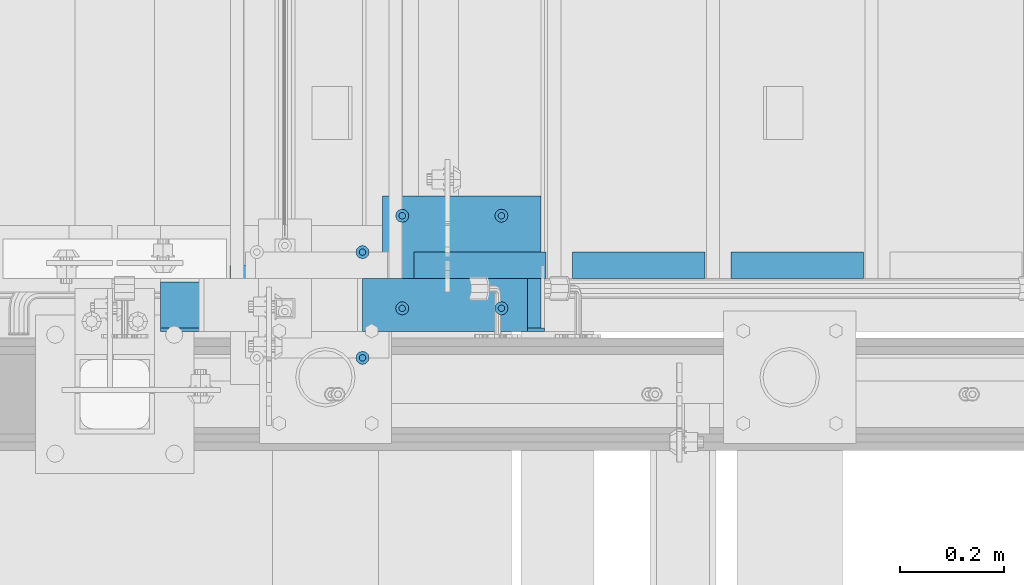
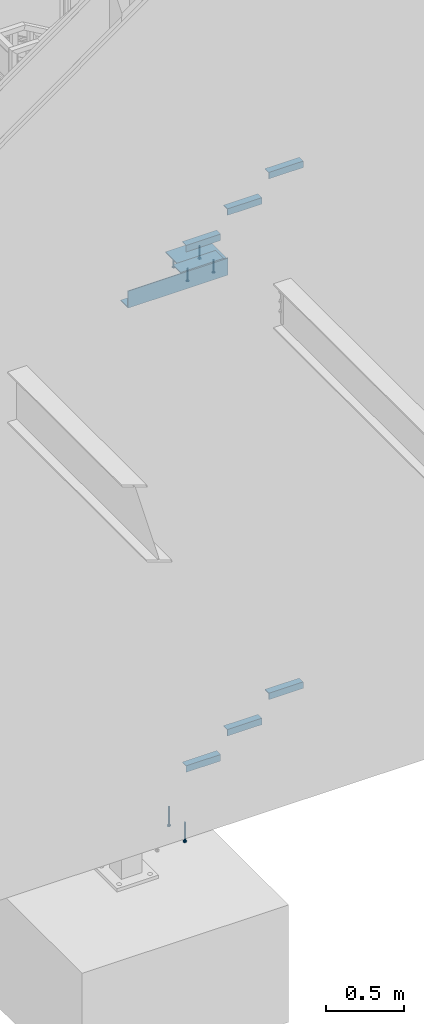
# One storey, part 905 of 1179: 15 beams, 5 elements without a shape of their own.
"""IFC2X3 building model written with IfcOpenShell, lengths in millimetres."""

from ifc_helpers import new_model, si_unit, frame, origin_with_axes, place, context, subcontext, project, spatial, faceted_brep, material, type_object, element, aggregate, save


model = new_model("IFC2X3")

# Units and contexts
model_context = context("Model", 3, precision=1e-05, world=origin_with_axes())
body_context = subcontext(model_context, "Body", "Model", "MODEL_VIEW")
ifc_project = project(units=[si_unit("LENGTHUNIT", "METRE", prefix="MILLI"), si_unit("AREAUNIT", "SQUARE_METRE"), si_unit("VOLUMEUNIT", "CUBIC_METRE"), si_unit("MASSUNIT", "GRAM", prefix="KILO"), si_unit("TIMEUNIT", "SECOND"), si_unit("PLANEANGLEUNIT", "RADIAN"), si_unit("SOLIDANGLEUNIT", "STERADIAN"), si_unit("THERMODYNAMICTEMPERATUREUNIT", "DEGREE_CELSIUS"), si_unit("LUMINOUSINTENSITYUNIT", "LUMEN")], contexts=[model_context])

# Site, building, storey
site_placement = place(None, origin_with_axes())
site = spatial("IfcSite", under=ifc_project, at=site_placement, CompositionType="ELEMENT")
building_placement = place(site_placement, origin_with_axes())
building = spatial("IfcBuilding", under=site, at=building_placement, Name="Undefined", CompositionType="ELEMENT")
storey_placement = place(building_placement, origin_with_axes())
storey = spatial("IfcBuildingStorey", under=building, at=storey_placement, Name="Undefined", CompositionType="ELEMENT", Elevation=0.0)

# Assembly, beams
assembly_1_placement = place(storey_placement, origin_with_axes())
assembly_1 = element("IfcElementAssembly", 1, at=assembly_1_placement, inside=storey, Name="STAIR", AssemblyPlace="NOTDEFINED", PredefinedType="RIGID_FRAME")
ifc_material_1 = material(Name="STEEL/A36")
beam_type_1 = type_object("IfcBeamType", Name="L2X2X3/16", PredefinedType="NOTDEFINED")
beam_1_placement = place(assembly_1_placement, frame((20717.213033546, 38233.3500001282, 4690.07030000019), z_axis=(0.0, 1.0, 0.0), x_axis=(-1.0, 0.0, 0.0)))
beam_1 = element("IfcBeam", 2, at=beam_1_placement, type_object=beam_type_1, material=ifc_material_1, Name="ANGLE", ObjectType="L2X2X3/16", context=body_context, shape_type="Brep", body=[
    faceted_brep([(0.0, 25.3999999999996, -25.4000000000015), (0.0, 25.3999999999996, 25.4000000000015), (254.0, 25.3999999999996, 25.4000000000001), (254.0, 25.3999999999996, -25.4000000000001), (0.0, 20.6374999999998, 25.4000000000015), (254.0, 20.6374999999998, 25.4000000000001), (0.0, 20.6374999999998, -20.6374999999971), (254.0, 20.6374999999998, -20.6374999999998), (0.0, -25.3999999999996, -20.6374999999971), (254.0, -25.3999999999996, -20.6374999999998), (0.0, -25.3999999999996, -25.4000000000015), (254.0, -25.3999999999996, -25.4000000000001)], [[[0, 1, 2, 3]], [[1, 4, 5, 2]], [[4, 6, 7, 5]], [[6, 8, 9, 7]], [[8, 10, 11, 9]], [[10, 0, 3, 11]], [[5, 7, 9, 11, 3, 2]], [[10, 8, 6, 4, 1, 0]]]),
])
beam_2_placement = place(assembly_1_placement, frame((20412.4130335689, 38233.3500001282, 4512.27030000019), z_axis=(0.0, 1.0, 0.0), x_axis=(-1.0, 0.0, 0.0)))
beam_2 = element("IfcBeam", 3, at=beam_2_placement, type_object=beam_type_1, material=ifc_material_1, Name="ANGLE", ObjectType="L2X2X3/16", context=body_context, shape_type="Brep", body=[
    faceted_brep([(0.0, 25.3999999999996, -25.4000000000015), (0.0, 25.3999999999996, 25.4000000000015), (254.0, 25.3999999999996, 25.4000000000001), (254.0, 25.3999999999996, -25.4000000000001), (0.0, 20.6374999999998, 25.4000000000015), (254.0, 20.6374999999998, 25.4000000000001), (0.0, 20.6374999999998, -20.6374999999971), (254.0, 20.6374999999998, -20.6374999999998), (0.0, -25.3999999999996, -20.6374999999971), (254.0, -25.3999999999996, -20.6374999999998), (0.0, -25.3999999999996, -25.4000000000015), (254.0, -25.3999999999996, -25.4000000000001)], [[[0, 1, 2, 3]], [[1, 4, 5, 2]], [[4, 6, 7, 5]], [[6, 8, 9, 7]], [[8, 10, 11, 9]], [[10, 0, 3, 11]], [[5, 7, 9, 11, 3, 2]], [[10, 8, 6, 4, 1, 0]]]),
])
beam_3_placement = place(assembly_1_placement, frame((20107.6130335918, 38233.3500001282, 4334.47030000019), z_axis=(0.0, 1.0, 0.0), x_axis=(-1.0, 0.0, 0.0)))
beam_3 = element("IfcBeam", 4, at=beam_3_placement, type_object=beam_type_1, material=ifc_material_1, Name="ANGLE", ObjectType="L2X2X3/16", context=body_context, shape_type="Brep", body=[
    faceted_brep([(0.0, 25.3999999999996, -25.4000000000015), (0.0, 25.3999999999996, 25.4000000000015), (254.0, 25.3999999999996, 25.4000000000001), (254.0, 25.3999999999996, -25.4000000000001), (0.0, 20.6374999999998, 25.4000000000015), (254.0, 20.6374999999998, 25.4000000000001), (0.0, 20.6374999999998, -20.6374999999971), (254.0, 20.6374999999998, -20.6374999999998), (0.0, -25.3999999999996, -20.6374999999971), (254.0, -25.3999999999996, -20.6374999999998), (0.0, -25.3999999999996, -25.4000000000015), (254.0, -25.3999999999996, -25.4000000000001)], [[[0, 1, 2, 3]], [[1, 4, 5, 2]], [[4, 6, 7, 5]], [[6, 8, 9, 7]], [[8, 10, 11, 9]], [[10, 0, 3, 11]], [[5, 7, 9, 11, 3, 2]], [[10, 8, 6, 4, 1, 0]]]),
])

assembly_2_placement = place(storey_placement, origin_with_axes())
assembly_2 = element("IfcElementAssembly", 5, at=assembly_2_placement, inside=storey, Name="STAIR", AssemblyPlace="NOTDEFINED", PredefinedType="RIGID_FRAME")
beam_4_placement = place(assembly_2_placement, frame((20717.2678270794, 38233.3500000346, 627.128633117604), z_axis=(0.0, 1.0, 0.0), x_axis=(-1.0, 0.0, 0.0)))
beam_4 = element("IfcBeam", 6, at=beam_4_placement, type_object=beam_type_1, material=ifc_material_1, Name="ANGLE", ObjectType="L2X2X3/16", context=body_context, shape_type="Brep", body=[
    faceted_brep([(0.0, 25.3999999999996, -25.4000000000015), (0.0, 25.3999999999996, 25.4000000000015), (254.0, 25.3999999999996, 25.4000000000001), (254.0, 25.3999999999996, -25.4000000000001), (0.0, 20.6374999999998, 25.4000000000015), (254.0, 20.6374999999998, 25.4000000000001), (0.0, 20.6374999999998, -20.6374999999971), (254.0, 20.6374999999998, -20.6374999999998), (0.0, -25.3999999999996, -20.6374999999971), (254.0, -25.3999999999996, -20.6374999999998), (0.0, -25.3999999999996, -25.4000000000015), (254.0, -25.3999999999996, -25.4000000000001)], [[[0, 1, 2, 3]], [[1, 4, 5, 2]], [[4, 6, 7, 5]], [[6, 8, 9, 7]], [[8, 10, 11, 9]], [[10, 0, 3, 11]], [[5, 7, 9, 11, 3, 2]], [[10, 8, 6, 4, 1, 0]]]),
])
beam_5_placement = place(assembly_2_placement, frame((20412.4678270527, 38233.3500000359, 450.651549838405), z_axis=(0.0, 1.0, 0.0), x_axis=(-1.0, 0.0, 0.0)))
beam_5 = element("IfcBeam", 7, at=beam_5_placement, type_object=beam_type_1, material=ifc_material_1, Name="ANGLE", ObjectType="L2X2X3/16", context=body_context, shape_type="Brep", body=[
    faceted_brep([(0.0, 25.3999999999996, -25.4000000000015), (0.0, 25.3999999999996, 25.4000000000015), (254.0, 25.3999999999996, 25.4000000000001), (254.0, 25.3999999999996, -25.4000000000001), (0.0, 20.6374999999998, 25.4000000000015), (254.0, 20.6374999999998, 25.4000000000001), (0.0, 20.6374999999998, -20.6374999999971), (254.0, 20.6374999999998, -20.6374999999998), (0.0, -25.3999999999996, -20.6374999999971), (254.0, -25.3999999999996, -20.6374999999998), (0.0, -25.3999999999996, -25.4000000000015), (254.0, -25.3999999999996, -25.4000000000001)], [[[0, 1, 2, 3]], [[1, 4, 5, 2]], [[4, 6, 7, 5]], [[6, 8, 9, 7]], [[8, 10, 11, 9]], [[10, 0, 3, 11]], [[5, 7, 9, 11, 3, 2]], [[10, 8, 6, 4, 1, 0]]]),
])
beam_6_placement = place(assembly_2_placement, frame((20107.6678270259, 38233.3500000371, 274.174466559207), z_axis=(0.0, 1.0, 0.0), x_axis=(-1.0, 0.0, 0.0)))
beam_6 = element("IfcBeam", 8, at=beam_6_placement, type_object=beam_type_1, material=ifc_material_1, Name="ANGLE", ObjectType="L2X2X3/16", context=body_context, shape_type="Brep", body=[
    faceted_brep([(0.0, 25.3999999999996, -25.4000000000015), (0.0, 25.3999999999996, 25.4000000000015), (254.0, 25.3999999999996, 25.4000000000001), (254.0, 25.3999999999996, -25.4000000000001), (0.0, 20.6374999999998, 25.4000000000015), (254.0, 20.6374999999998, 25.4000000000001), (0.0, 20.6374999999998, -20.6374999999971), (254.0, 20.6374999999998, -20.6374999999998), (0.0, -25.3999999999996, -20.6374999999971), (254.0, -25.3999999999996, -20.6374999999998), (0.0, -25.3999999999996, -25.4000000000015), (254.0, -25.3999999999996, -25.4000000000001)], [[[0, 1, 2, 3]], [[1, 4, 5, 2]], [[4, 6, 7, 5]], [[6, 8, 9, 7]], [[8, 10, 11, 9]], [[10, 0, 3, 11]], [[5, 7, 9, 11, 3, 2]], [[10, 8, 6, 4, 1, 0]]]),
])
aggregate(assembly_2, [beam_4, beam_5, beam_6])

assembly_3_placement = place(storey_placement, origin_with_axes())
assembly_3 = element("IfcElementAssembly", 9, at=assembly_3_placement, inside=storey, Name="EMBED", AssemblyPlace="NOTDEFINED", PredefinedType="RIGID_FRAME")
ifc_material_2 = material(Name="STEEL/A108")
beam_type_2 = type_object("IfcBeamType", Name="STUD_1/2-DIA", PredefinedType="NOTDEFINED")
beam_7_placement = place(assembly_3_placement, frame((20021.55, 38150.8000000005, 4225.925), z_axis=(0.0, -1.0, 0.0), x_axis=(0.0, 0.0, -1.0)))
beam_7 = element("IfcBeam", 10, at=beam_7_placement, type_object=beam_type_2, material=ifc_material_2, Name="SHEAR STUD", ObjectType="STUD_1/2-DIA", context=body_context, shape_type="Brep", body=[
    faceted_brep([(0.0, -3.1800000667572, 5.5), (0.0, -5.5, 3.1800000667572), (94.4880000000003, -5.5, 3.1800000667572), (94.4880000000003, -3.1800000667572, 5.5), (0.0, -6.34999999999854, 0.0), (94.4880000000003, -6.34999990463257, 0.0), (0.0, -5.5, -3.1800000667572), (94.4880000000003, -5.5, -3.1800000667572), (0.0, -3.1800000667572, -5.5), (94.4880000000003, -3.1800000667572, -5.5), (0.0, 0.0, -6.34999999999991), (94.4880000000003, 0.0, -6.34999990463257), (0.0, 3.1800000667572, -5.5), (94.4880000000003, 3.1800000667572, -5.5), (0.0, 5.5, -3.1800000667572), (94.4880000000003, 5.5, -3.1800000667572), (0.0, 6.34999999999854, 0.0), (94.4880000000003, 6.34999990463257, 0.0), (0.0, 5.5, 3.1800000667572), (94.4880000000003, 5.5, 3.1800000667572), (0.0, 3.1800000667572, 5.5), (94.4880000000003, 3.1800000667572, 5.5), (0.0, 0.0, 6.34999999999991), (94.4880000000003, 0.0, 6.34999990463257), (96.5200000000004, -10.9899997711182, 6.34999990463257), (96.5200000000004, -6.34000015258789, 10.9899997711182), (96.5200000000004, -12.6999998092651, 0.0), (96.5200000000004, -10.9899997711182, -6.34999990463257), (96.5200000000004, -6.34000015258789, -10.9899997711182), (96.5200000000004, 0.0, -12.6899995803833), (96.5200000000004, 6.34000015258789, -10.9899997711182), (96.5200000000004, 10.9899997711182, -6.34999990463257), (96.5200000000004, 12.6999998092651, 0.0), (96.5200000000004, 10.9899997711182, 6.34999990463257), (96.5200000000004, 6.34000015258789, 10.9899997711182), (96.5200000000004, 0.0, 12.6899995803833), (101.6, -10.9899997711182, 6.34999990463257), (101.6, -6.34000015258789, 10.9899997711182), (101.6, -12.6999998092651, 0.0), (101.6, -10.9899997711182, -6.34999990463257), (101.6, -6.34000015258789, -10.9899997711182), (101.6, 0.0, -12.6899995803833), (101.6, 6.34000015258789, -10.9899997711182), (101.6, 10.9899997711182, -6.34999990463257), (101.6, 12.6999998092651, 0.0), (101.6, 10.9899997711182, 6.34999990463257), (101.6, 6.34000015258789, 10.9899997711182), (101.6, 0.0, 12.6899995803833)], [[[0, 1, 2, 3]], [[1, 4, 5, 2]], [[4, 6, 7, 5]], [[6, 8, 9, 7]], [[8, 10, 11, 9]], [[10, 12, 13, 11]], [[12, 14, 15, 13]], [[14, 16, 17, 15]], [[16, 18, 19, 17]], [[18, 20, 21, 19]], [[20, 22, 23, 21]], [[22, 0, 3, 23]], [[22, 20, 18, 16, 14, 12, 10, 8, 6, 4, 1, 0]], [[3, 2, 24, 25]], [[2, 5, 26, 24]], [[5, 7, 27, 26]], [[7, 9, 28, 27]], [[9, 11, 29, 28]], [[11, 13, 30, 29]], [[13, 15, 31, 30]], [[15, 17, 32, 31]], [[17, 19, 33, 32]], [[19, 21, 34, 33]], [[21, 23, 35, 34]], [[23, 3, 25, 35]], [[25, 24, 36, 37]], [[24, 26, 38, 36]], [[26, 27, 39, 38]], [[27, 28, 40, 39]], [[28, 29, 41, 40]], [[29, 30, 42, 41]], [[30, 31, 43, 42]], [[31, 32, 44, 43]], [[32, 33, 45, 44]], [[33, 34, 46, 45]], [[34, 35, 47, 46]], [[35, 25, 37, 47]], [[38, 39, 40, 41, 42, 43, 44, 45, 46, 47, 37, 36]]]),
])
beam_8_placement = place(assembly_3_placement, frame((19831.05, 38150.8000000005, 4225.925), z_axis=(0.0, -1.0, 0.0), x_axis=(0.0, 0.0, -1.0)))
beam_8 = element("IfcBeam", 11, at=beam_8_placement, type_object=beam_type_2, material=ifc_material_2, Name="SHEAR STUD", ObjectType="STUD_1/2-DIA", context=body_context, shape_type="Brep", body=[
    faceted_brep([(0.0, -3.1800000667572, 5.5), (0.0, -5.5, 3.1800000667572), (94.4880000000003, -5.5, 3.1800000667572), (94.4880000000003, -3.1800000667572, 5.5), (0.0, -6.34999999999854, 0.0), (94.4880000000003, -6.34999990463257, 0.0), (0.0, -5.5, -3.1800000667572), (94.4880000000003, -5.5, -3.1800000667572), (0.0, -3.1800000667572, -5.5), (94.4880000000003, -3.1800000667572, -5.5), (0.0, 0.0, -6.34999999999991), (94.4880000000003, 0.0, -6.34999990463257), (0.0, 3.1800000667572, -5.5), (94.4880000000003, 3.1800000667572, -5.5), (0.0, 5.5, -3.1800000667572), (94.4880000000003, 5.5, -3.1800000667572), (0.0, 6.34999999999854, 0.0), (94.4880000000003, 6.34999990463257, 0.0), (0.0, 5.5, 3.1800000667572), (94.4880000000003, 5.5, 3.1800000667572), (0.0, 3.1800000667572, 5.5), (94.4880000000003, 3.1800000667572, 5.5), (0.0, 0.0, 6.34999999999991), (94.4880000000003, 0.0, 6.34999990463257), (96.5200000000004, -10.9899997711182, 6.34999990463257), (96.5200000000004, -6.34000015258789, 10.9899997711182), (96.5200000000004, -12.6999998092651, 0.0), (96.5200000000004, -10.9899997711182, -6.34999990463257), (96.5200000000004, -6.34000015258789, -10.9899997711182), (96.5200000000004, 0.0, -12.6899995803833), (96.5200000000004, 6.34000015258789, -10.9899997711182), (96.5200000000004, 10.9899997711182, -6.34999990463257), (96.5200000000004, 12.6999998092651, 0.0), (96.5200000000004, 10.9899997711182, 6.34999990463257), (96.5200000000004, 6.34000015258789, 10.9899997711182), (96.5200000000004, 0.0, 12.6899995803833), (101.6, -10.9899997711182, 6.34999990463257), (101.6, -6.34000015258789, 10.9899997711182), (101.6, -12.6999998092651, 0.0), (101.6, -10.9899997711182, -6.34999990463257), (101.6, -6.34000015258789, -10.9899997711182), (101.6, 0.0, -12.6899995803833), (101.6, 6.34000015258789, -10.9899997711182), (101.6, 10.9899997711182, -6.34999990463257), (101.6, 12.6999998092651, 0.0), (101.6, 10.9899997711182, 6.34999990463257), (101.6, 6.34000015258789, 10.9899997711182), (101.6, 0.0, 12.6899995803833)], [[[0, 1, 2, 3]], [[1, 4, 5, 2]], [[4, 6, 7, 5]], [[6, 8, 9, 7]], [[8, 10, 11, 9]], [[10, 12, 13, 11]], [[12, 14, 15, 13]], [[14, 16, 17, 15]], [[16, 18, 19, 17]], [[18, 20, 21, 19]], [[20, 22, 23, 21]], [[22, 0, 3, 23]], [[22, 20, 18, 16, 14, 12, 10, 8, 6, 4, 1, 0]], [[3, 2, 24, 25]], [[2, 5, 26, 24]], [[5, 7, 27, 26]], [[7, 9, 28, 27]], [[9, 11, 29, 28]], [[11, 13, 30, 29]], [[13, 15, 31, 30]], [[15, 17, 32, 31]], [[17, 19, 33, 32]], [[19, 21, 34, 33]], [[21, 23, 35, 34]], [[23, 3, 25, 35]], [[25, 24, 36, 37]], [[24, 26, 38, 36]], [[26, 27, 39, 38]], [[27, 28, 40, 39]], [[28, 29, 41, 40]], [[29, 30, 42, 41]], [[30, 31, 43, 42]], [[31, 32, 44, 43]], [[32, 33, 45, 44]], [[33, 34, 46, 45]], [[34, 35, 47, 46]], [[35, 25, 37, 47]], [[38, 39, 40, 41, 42, 43, 44, 45, 46, 47, 37, 36]]]),
])
beam_9_placement = place(assembly_3_placement, frame((20021.55, 38328.6000000005, 4225.925), z_axis=(0.0, -1.0, 0.0), x_axis=(0.0, 0.0, -1.0)))
beam_9 = element("IfcBeam", 12, at=beam_9_placement, type_object=beam_type_2, material=ifc_material_2, Name="SHEAR STUD", ObjectType="STUD_1/2-DIA", context=body_context, shape_type="Brep", body=[
    faceted_brep([(0.0, -3.1800000667572, 5.5), (0.0, -5.5, 3.1800000667572), (94.4880000000003, -5.5, 3.1800000667572), (94.4880000000003, -3.1800000667572, 5.5), (0.0, -6.34999999999854, 0.0), (94.4880000000003, -6.34999990463257, 0.0), (0.0, -5.5, -3.1800000667572), (94.4880000000003, -5.5, -3.1800000667572), (0.0, -3.1800000667572, -5.5), (94.4880000000003, -3.1800000667572, -5.5), (0.0, 0.0, -6.34999999999991), (94.4880000000003, 0.0, -6.34999990463257), (0.0, 3.1800000667572, -5.5), (94.4880000000003, 3.1800000667572, -5.5), (0.0, 5.5, -3.1800000667572), (94.4880000000003, 5.5, -3.1800000667572), (0.0, 6.34999999999854, 0.0), (94.4880000000003, 6.34999990463257, 0.0), (0.0, 5.5, 3.1800000667572), (94.4880000000003, 5.5, 3.1800000667572), (0.0, 3.1800000667572, 5.5), (94.4880000000003, 3.1800000667572, 5.5), (0.0, 0.0, 6.34999999999991), (94.4880000000003, 0.0, 6.34999990463257), (96.5200000000004, -10.9899997711182, 6.34999990463257), (96.5200000000004, -6.34000015258789, 10.9899997711182), (96.5200000000004, -12.6999998092651, 0.0), (96.5200000000004, -10.9899997711182, -6.34999990463257), (96.5200000000004, -6.34000015258789, -10.9899997711182), (96.5200000000004, 0.0, -12.6899995803833), (96.5200000000004, 6.34000015258789, -10.9899997711182), (96.5200000000004, 10.9899997711182, -6.34999990463257), (96.5200000000004, 12.6999998092651, 0.0), (96.5200000000004, 10.9899997711182, 6.34999990463257), (96.5200000000004, 6.34000015258789, 10.9899997711182), (96.5200000000004, 0.0, 12.6899995803833), (101.6, -10.9899997711182, 6.34999990463257), (101.6, -6.34000015258789, 10.9899997711182), (101.6, -12.6999998092651, 0.0), (101.6, -10.9899997711182, -6.34999990463257), (101.6, -6.34000015258789, -10.9899997711182), (101.6, 0.0, -12.6899995803833), (101.6, 6.34000015258789, -10.9899997711182), (101.6, 10.9899997711182, -6.34999990463257), (101.6, 12.6999998092651, 0.0), (101.6, 10.9899997711182, 6.34999990463257), (101.6, 6.34000015258789, 10.9899997711182), (101.6, 0.0, 12.6899995803833)], [[[0, 1, 2, 3]], [[1, 4, 5, 2]], [[4, 6, 7, 5]], [[6, 8, 9, 7]], [[8, 10, 11, 9]], [[10, 12, 13, 11]], [[12, 14, 15, 13]], [[14, 16, 17, 15]], [[16, 18, 19, 17]], [[18, 20, 21, 19]], [[20, 22, 23, 21]], [[22, 0, 3, 23]], [[22, 20, 18, 16, 14, 12, 10, 8, 6, 4, 1, 0]], [[3, 2, 24, 25]], [[2, 5, 26, 24]], [[5, 7, 27, 26]], [[7, 9, 28, 27]], [[9, 11, 29, 28]], [[11, 13, 30, 29]], [[13, 15, 31, 30]], [[15, 17, 32, 31]], [[17, 19, 33, 32]], [[19, 21, 34, 33]], [[21, 23, 35, 34]], [[23, 3, 25, 35]], [[25, 24, 36, 37]], [[24, 26, 38, 36]], [[26, 27, 39, 38]], [[27, 28, 40, 39]], [[28, 29, 41, 40]], [[29, 30, 42, 41]], [[30, 31, 43, 42]], [[31, 32, 44, 43]], [[32, 33, 45, 44]], [[33, 34, 46, 45]], [[34, 35, 47, 46]], [[35, 25, 37, 47]], [[38, 39, 40, 41, 42, 43, 44, 45, 46, 47, 37, 36]]]),
])
beam_10_placement = place(assembly_3_placement, frame((19831.05, 38328.6000000005, 4225.925), z_axis=(0.0, -1.0, 0.0), x_axis=(0.0, 0.0, -1.0)))
beam_10 = element("IfcBeam", 13, at=beam_10_placement, type_object=beam_type_2, material=ifc_material_2, Name="SHEAR STUD", ObjectType="STUD_1/2-DIA", context=body_context, shape_type="Brep", body=[
    faceted_brep([(0.0, -3.1800000667572, 5.5), (0.0, -5.5, 3.1800000667572), (94.4880000000003, -5.5, 3.1800000667572), (94.4880000000003, -3.1800000667572, 5.5), (0.0, -6.34999999999854, 0.0), (94.4880000000003, -6.34999990463257, 0.0), (0.0, -5.5, -3.1800000667572), (94.4880000000003, -5.5, -3.1800000667572), (0.0, -3.1800000667572, -5.5), (94.4880000000003, -3.1800000667572, -5.5), (0.0, 0.0, -6.34999999999991), (94.4880000000003, 0.0, -6.34999990463257), (0.0, 3.1800000667572, -5.5), (94.4880000000003, 3.1800000667572, -5.5), (0.0, 5.5, -3.1800000667572), (94.4880000000003, 5.5, -3.1800000667572), (0.0, 6.34999999999854, 0.0), (94.4880000000003, 6.34999990463257, 0.0), (0.0, 5.5, 3.1800000667572), (94.4880000000003, 5.5, 3.1800000667572), (0.0, 3.1800000667572, 5.5), (94.4880000000003, 3.1800000667572, 5.5), (0.0, 0.0, 6.34999999999991), (94.4880000000003, 0.0, 6.34999990463257), (96.5200000000004, -10.9899997711182, 6.34999990463257), (96.5200000000004, -6.34000015258789, 10.9899997711182), (96.5200000000004, -12.6999998092651, 0.0), (96.5200000000004, -10.9899997711182, -6.34999990463257), (96.5200000000004, -6.34000015258789, -10.9899997711182), (96.5200000000004, 0.0, -12.6899995803833), (96.5200000000004, 6.34000015258789, -10.9899997711182), (96.5200000000004, 10.9899997711182, -6.34999990463257), (96.5200000000004, 12.6999998092651, 0.0), (96.5200000000004, 10.9899997711182, 6.34999990463257), (96.5200000000004, 6.34000015258789, 10.9899997711182), (96.5200000000004, 0.0, 12.6899995803833), (101.6, -10.9899997711182, 6.34999990463257), (101.6, -6.34000015258789, 10.9899997711182), (101.6, -12.6999998092651, 0.0), (101.6, -10.9899997711182, -6.34999990463257), (101.6, -6.34000015258789, -10.9899997711182), (101.6, 0.0, -12.6899995803833), (101.6, 6.34000015258789, -10.9899997711182), (101.6, 10.9899997711182, -6.34999990463257), (101.6, 12.6999998092651, 0.0), (101.6, 10.9899997711182, 6.34999990463257), (101.6, 6.34000015258789, 10.9899997711182), (101.6, 0.0, 12.6899995803833)], [[[0, 1, 2, 3]], [[1, 4, 5, 2]], [[4, 6, 7, 5]], [[6, 8, 9, 7]], [[8, 10, 11, 9]], [[10, 12, 13, 11]], [[12, 14, 15, 13]], [[14, 16, 17, 15]], [[16, 18, 19, 17]], [[18, 20, 21, 19]], [[20, 22, 23, 21]], [[22, 0, 3, 23]], [[22, 20, 18, 16, 14, 12, 10, 8, 6, 4, 1, 0]], [[3, 2, 24, 25]], [[2, 5, 26, 24]], [[5, 7, 27, 26]], [[7, 9, 28, 27]], [[9, 11, 29, 28]], [[11, 13, 30, 29]], [[13, 15, 31, 30]], [[15, 17, 32, 31]], [[17, 19, 33, 32]], [[19, 21, 34, 33]], [[21, 23, 35, 34]], [[23, 3, 25, 35]], [[25, 24, 36, 37]], [[24, 26, 38, 36]], [[26, 27, 39, 38]], [[27, 28, 40, 39]], [[28, 29, 41, 40]], [[29, 30, 42, 41]], [[30, 31, 43, 42]], [[31, 32, 44, 43]], [[32, 33, 45, 44]], [[33, 34, 46, 45]], [[34, 35, 47, 46]], [[35, 25, 37, 47]], [[38, 39, 40, 41, 42, 43, 44, 45, 46, 47, 37, 36]]]),
])

assembly_4_placement = place(storey_placement, origin_with_axes())
assembly_4 = element("IfcElementAssembly", 14, at=assembly_4_placement, inside=storey, Name="EMBED", AssemblyPlace="NOTDEFINED", PredefinedType="RIGID_FRAME")
beam_11_placement = place(assembly_4_placement, frame((19754.8500003795, 38055.5499999969, -12.6999999999994), z_axis=(0.0, -1.0, 0.0), x_axis=(0.0, 0.0, -1.0)))
beam_11 = element("IfcBeam", 15, at=beam_11_placement, type_object=beam_type_2, material=ifc_material_2, Name="SHEAR STUD", ObjectType="STUD_1/2-DIA", context=body_context, shape_type="Brep", body=[
    faceted_brep([(0.0, -3.1800000667572, 5.5), (0.0, -5.5, 3.1800000667572), (141.732, -5.5, 3.1800000667572), (141.732, -3.1800000667572, 5.5), (0.0, -6.34999999999854, 0.0), (141.732, -6.34999990463257, 0.0), (0.0, -5.5, -3.1800000667572), (141.732, -5.5, -3.1800000667572), (0.0, -3.1800000667572, -5.5), (141.732, -3.1800000667572, -5.5), (0.0, 0.0, -6.34999999999991), (141.732, 0.0, -6.34999990463257), (0.0, 3.1800000667572, -5.5), (141.732, 3.1800000667572, -5.5), (0.0, 5.5, -3.1800000667572), (141.732, 5.5, -3.1800000667572), (0.0, 6.34999999999854, 0.0), (141.732, 6.34999990463257, 0.0), (0.0, 5.5, 3.1800000667572), (141.732, 5.5, 3.1800000667572), (0.0, 3.1800000667572, 5.5), (141.732, 3.1800000667572, 5.5), (0.0, 0.0, 6.34999999999991), (141.732, 0.0, 6.34999990463257), (144.78, -10.9899997711182, 6.34999990463257), (144.78, -6.34000015258789, 10.9899997711182), (144.78, -12.6999998092651, 0.0), (144.78, -10.9899997711182, -6.34999990463257), (144.78, -6.34000015258789, -10.9899997711182), (144.78, 0.0, -12.6899995803833), (144.78, 6.34000015258789, -10.9899997711182), (144.78, 10.9899997711182, -6.34999990463257), (144.78, 12.6999998092651, 0.0), (144.78, 10.9899997711182, 6.34999990463257), (144.78, 6.34000015258789, 10.9899997711182), (144.78, 0.0, 12.6899995803833), (152.4, -10.9899997711182, 6.34999990463257), (152.4, -6.34000015258789, 10.9899997711182), (152.4, -12.6999998092651, 0.0), (152.4, -10.9899997711182, -6.34999990463257), (152.4, -6.34000015258789, -10.9899997711182), (152.4, 0.0, -12.6899995803833), (152.4, 6.34000015258789, -10.9899997711182), (152.4, 10.9899997711182, -6.34999990463257), (152.4, 12.6999998092651, 0.0), (152.4, 10.9899997711182, 6.34999990463257), (152.4, 6.34000015258789, 10.9899997711182), (152.4, 0.0, 12.6899995803833)], [[[0, 1, 2, 3]], [[1, 4, 5, 2]], [[4, 6, 7, 5]], [[6, 8, 9, 7]], [[8, 10, 11, 9]], [[10, 12, 13, 11]], [[12, 14, 15, 13]], [[14, 16, 17, 15]], [[16, 18, 19, 17]], [[18, 20, 21, 19]], [[20, 22, 23, 21]], [[22, 0, 3, 23]], [[22, 20, 18, 16, 14, 12, 10, 8, 6, 4, 1, 0]], [[3, 2, 24, 25]], [[2, 5, 26, 24]], [[5, 7, 27, 26]], [[7, 9, 28, 27]], [[9, 11, 29, 28]], [[11, 13, 30, 29]], [[13, 15, 31, 30]], [[15, 17, 32, 31]], [[17, 19, 33, 32]], [[19, 21, 34, 33]], [[21, 23, 35, 34]], [[23, 3, 25, 35]], [[25, 24, 36, 37]], [[24, 26, 38, 36]], [[26, 27, 39, 38]], [[27, 28, 40, 39]], [[28, 29, 41, 40]], [[29, 30, 42, 41]], [[30, 31, 43, 42]], [[31, 32, 44, 43]], [[32, 33, 45, 44]], [[33, 34, 46, 45]], [[34, 35, 47, 46]], [[35, 25, 37, 47]], [[38, 39, 40, 41, 42, 43, 44, 45, 46, 47, 37, 36]]]),
])
beam_12_placement = place(assembly_4_placement, frame((19754.8500003795, 38258.7499999968, -12.6999999999994), z_axis=(0.0, -1.0, 0.0), x_axis=(0.0, 0.0, -1.0)))
beam_12 = element("IfcBeam", 16, at=beam_12_placement, type_object=beam_type_2, material=ifc_material_2, Name="SHEAR STUD", ObjectType="STUD_1/2-DIA", context=body_context, shape_type="Brep", body=[
    faceted_brep([(0.0, -3.1800000667572, 5.5), (0.0, -5.5, 3.1800000667572), (141.732, -5.5, 3.1800000667572), (141.732, -3.1800000667572, 5.5), (0.0, -6.34999999999854, 0.0), (141.732, -6.34999990463257, 0.0), (0.0, -5.5, -3.1800000667572), (141.732, -5.5, -3.1800000667572), (0.0, -3.1800000667572, -5.5), (141.732, -3.1800000667572, -5.5), (0.0, 0.0, -6.34999999999991), (141.732, 0.0, -6.34999990463257), (0.0, 3.1800000667572, -5.5), (141.732, 3.1800000667572, -5.5), (0.0, 5.5, -3.1800000667572), (141.732, 5.5, -3.1800000667572), (0.0, 6.34999999999854, 0.0), (141.732, 6.34999990463257, 0.0), (0.0, 5.5, 3.1800000667572), (141.732, 5.5, 3.1800000667572), (0.0, 3.1800000667572, 5.5), (141.732, 3.1800000667572, 5.5), (0.0, 0.0, 6.34999999999991), (141.732, 0.0, 6.34999990463257), (144.78, -10.9899997711182, 6.34999990463257), (144.78, -6.34000015258789, 10.9899997711182), (144.78, -12.6999998092651, 0.0), (144.78, -10.9899997711182, -6.34999990463257), (144.78, -6.34000015258789, -10.9899997711182), (144.78, 0.0, -12.6899995803833), (144.78, 6.34000015258789, -10.9899997711182), (144.78, 10.9899997711182, -6.34999990463257), (144.78, 12.6999998092651, 0.0), (144.78, 10.9899997711182, 6.34999990463257), (144.78, 6.34000015258789, 10.9899997711182), (144.78, 0.0, 12.6899995803833), (152.4, -10.9899997711182, 6.34999990463257), (152.4, -6.34000015258789, 10.9899997711182), (152.4, -12.6999998092651, 0.0), (152.4, -10.9899997711182, -6.34999990463257), (152.4, -6.34000015258789, -10.9899997711182), (152.4, 0.0, -12.6899995803833), (152.4, 6.34000015258789, -10.9899997711182), (152.4, 10.9899997711182, -6.34999990463257), (152.4, 12.6999998092651, 0.0), (152.4, 10.9899997711182, 6.34999990463257), (152.4, 6.34000015258789, 10.9899997711182), (152.4, 0.0, 12.6899995803833)], [[[0, 1, 2, 3]], [[1, 4, 5, 2]], [[4, 6, 7, 5]], [[6, 8, 9, 7]], [[8, 10, 11, 9]], [[10, 12, 13, 11]], [[12, 14, 15, 13]], [[14, 16, 17, 15]], [[16, 18, 19, 17]], [[18, 20, 21, 19]], [[20, 22, 23, 21]], [[22, 0, 3, 23]], [[22, 20, 18, 16, 14, 12, 10, 8, 6, 4, 1, 0]], [[3, 2, 24, 25]], [[2, 5, 26, 24]], [[5, 7, 27, 26]], [[7, 9, 28, 27]], [[9, 11, 29, 28]], [[11, 13, 30, 29]], [[13, 15, 31, 30]], [[15, 17, 32, 31]], [[17, 19, 33, 32]], [[19, 21, 34, 33]], [[21, 23, 35, 34]], [[23, 3, 25, 35]], [[25, 24, 36, 37]], [[24, 26, 38, 36]], [[26, 27, 39, 38]], [[27, 28, 40, 39]], [[28, 29, 41, 40]], [[29, 30, 42, 41]], [[30, 31, 43, 42]], [[31, 32, 44, 43]], [[32, 33, 45, 44]], [[33, 34, 46, 45]], [[34, 35, 47, 46]], [[35, 25, 37, 47]], [[38, 39, 40, 41, 42, 43, 44, 45, 46, 47, 37, 36]]]),
])
aggregate(assembly_4, [beam_11, beam_12])

# Beam
beam_type_3 = type_object("IfcBeamType", PredefinedType="NOTDEFINED")
beam_13_placement = place(assembly_1_placement, frame((19754.8499998473, 38157.1499999866, 4240.21250163247), z_axis=(0.0, -1.0, 0.0), x_axis=(1.0, 0.0, 0.0)))
beam_13 = element("IfcBeam", 17, at=beam_13_placement, type_object=beam_type_3, material=ifc_material_1, Name="PLATE", context=body_context, shape_type="Brep", body=[
    faceted_brep([(0.0, 4.76249999999982, -50.7999999999993), (0.0, 4.76249999999982, 50.7999999999993), (316.835553113491, 4.76250000001255, 50.8000000000029), (316.835553113491, 4.76250000001255, -50.8000000000029), (0.0, -4.76249999999982, 50.7999999999993), (316.835553113473, -4.76249999998709, 50.8000000000029), (0.0, -4.76249999999982, -50.7999999999993), (316.835553113473, -4.76249999998709, -50.8000000000029)], [[[0, 1, 2, 3]], [[1, 4, 5, 2]], [[4, 6, 7, 5]], [[6, 0, 3, 7]], [[5, 7, 3, 2]], [[6, 4, 1, 0]]]),
])

aggregate(assembly_1, [beam_13, beam_1, beam_2, beam_3])

beam_type_4 = type_object("IfcBeamType", PredefinedType="NOTDEFINED")
beam_14_placement = place(assembly_3_placement, frame((20097.75, 38239.7000000005, 4230.6875), z_axis=(0.0, 1.0, 0.0), x_axis=(-1.0, 0.0, 0.0)))
beam_14 = element("IfcBeam", 18, at=beam_14_placement, type_object=beam_type_4, material=ifc_material_1, Name="EMBED", context=body_context, shape_type="Brep", body=[
    faceted_brep([(0.0, 4.76249999999982, -127.0), (0.0, 4.76249999999709, 127.0), (304.799999999999, 4.76249999999982, 127.0), (304.799999999999, 4.76249999999982, -127.0), (0.0, -4.76249999999709, 127.0), (304.799999999999, -4.76249999999982, 127.0), (0.0, -4.76249999999982, -127.0), (304.799999999999, -4.76249999999982, -127.0)], [[[0, 1, 2, 3]], [[1, 4, 5, 2]], [[4, 6, 7, 5]], [[6, 0, 3, 7]], [[5, 7, 3, 2]], [[6, 4, 1, 0]]]),
])

aggregate(assembly_3, [beam_7, beam_8, beam_9, beam_10, beam_14])

# Assembly, beam
assembly_5_placement = place(storey_placement, origin_with_axes())
assembly_5 = element("IfcElementAssembly", 19, at=assembly_5_placement, inside=storey, Name="BEAM", AssemblyPlace="NOTDEFINED", PredefinedType="RIGID_FRAME")
beam_type_5 = type_object("IfcBeamType", PredefinedType="NOTDEFINED")
beam_15_placement = place(assembly_5_placement, frame((19735.40325, 38233.3500000005, 4105.275), z_axis=(-1.0, 0.0, 0.0), x_axis=(0.0, -1.0, 0.0)))
beam_15 = element("IfcBeam", 20, at=beam_15_placement, type_object=beam_type_5, material=ifc_material_1, Name="BENT_PLATE", context=body_context, shape_type="Brep", body=[
    faceted_brep([(31.7499999999927, -3.17500000000018, 235.347000000005), (31.7499999999927, 3.17500000000018, 235.347000000005), (0.0, 3.17500000000018, 235.347000000005), (0.0, -3.17500000000018, 235.347000000005), (31.7499999999927, -3.17500000000018, 368.697), (31.7499999999927, 3.17500000000018, 368.697), (127.0, -3.17500000000018, -368.697), (0.0, -3.17500000000018, -368.697), (0.0, 3.17500000000018, -368.697), (120.649999999994, 3.17500000000018, -368.697), (120.649999999994, 130.175, -368.697), (127.0, 130.175, -368.697), (120.649999999994, 3.17500000000018, 368.697), (120.649999999994, 130.175, 368.697), (127.0, 130.175, 368.697), (127.0, -3.17500000000018, 368.697)], [[[0, 1, 2, 3]], [[4, 5, 1, 0]], [[6, 7, 8, 9, 10, 11]], [[9, 12, 13, 10]], [[14, 11, 10, 13]], [[15, 6, 11, 14]], [[3, 7, 6, 15, 4, 0]], [[8, 7, 3, 2]], [[12, 9, 8, 2, 1, 5]], [[15, 14, 13, 12, 5, 4]]]),
])
aggregate(assembly_5, [beam_15])

save(model, "model.ifc")
